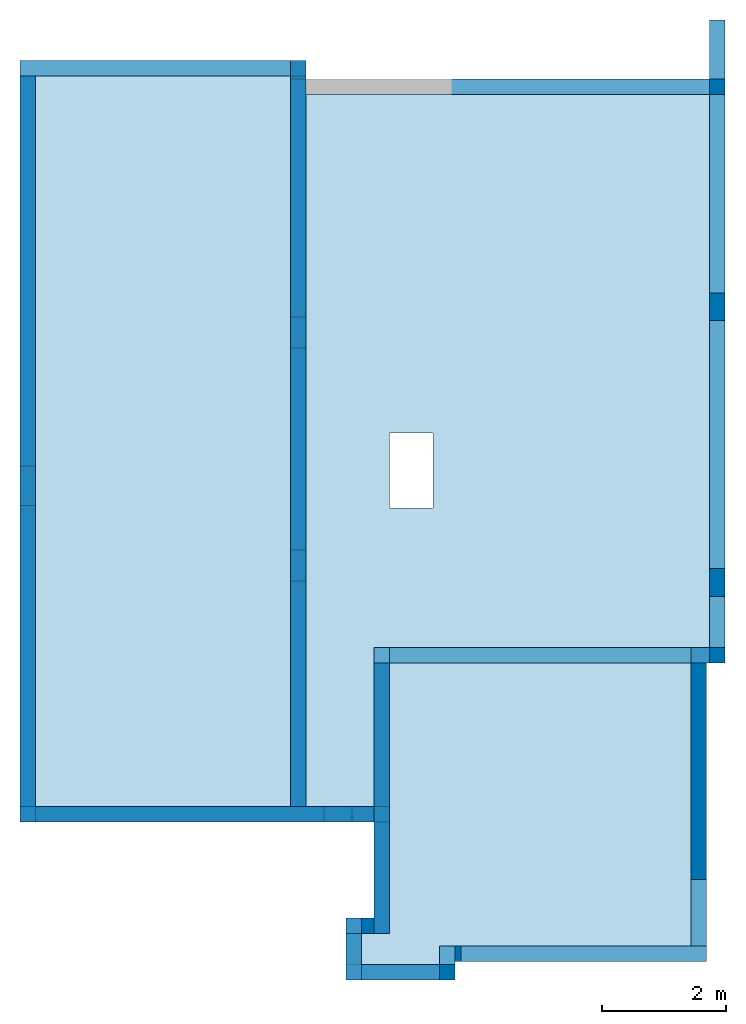
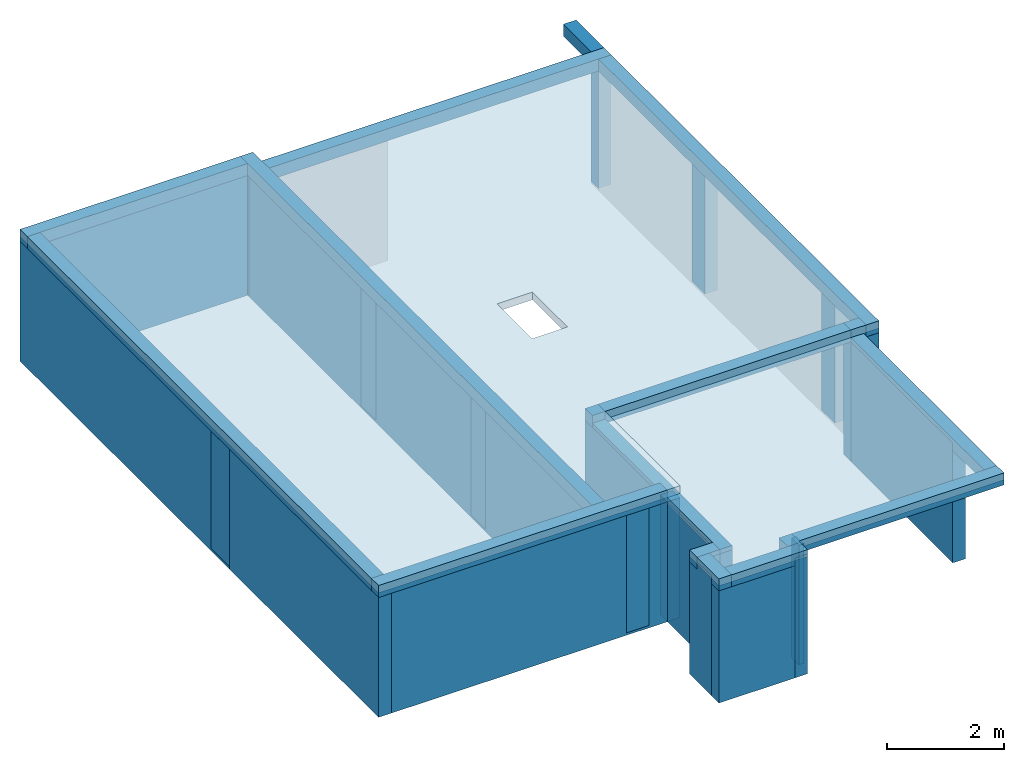
# One storey, part 1 of 2: 17 beams, 17 walls, 7 columns, 2 slabs.
"""IFC4 building model written with IfcOpenShell, lengths in millimetres."""

import ifcopenshell
import ifcopenshell.guid

model = None  # the IFC model being written
_history = None  # IfcOwnerHistory: only IFC2X3 demands one
_inside = {}  # id of a spatial element -> (the spatial element, [elements in it])
_under = {}  # id of a project, library or spatial element -> (it, [spatial elements below it])
_declared = {}  # id of a project -> (the project, [libraries it declares])
_typed = {}  # id of a type object -> (the type object, [elements of that type])
_made_of = {}  # id of a material, layer set ... -> (it, [elements and type objects made of it])


def new_model(schema):
    """Start an empty IFC model of exactly this schema.

    Asked for "IFC4X3", IfcOpenShell would pick the latest addendum, in which some entities
    have other attributes; the version numbers below select the first issue.
    IFC2X3 requires an IfcOwnerHistory on every rooted entity: one is made here for all.
    """
    global model, _history
    if schema == "IFC4X3":
        model = ifcopenshell.file(schema_version=(4, 3, 0, 0))
    else:
        model = ifcopenshell.file(schema=schema)
    _inside.clear()
    _under.clear()
    _declared.clear()
    _typed.clear()
    _made_of.clear()
    _history = None
    if model.schema == "IFC2X3":
        org = make("IfcOrganization", Name="unknown")
        user = make(
            "IfcPersonAndOrganization",
            ThePerson=make("IfcPerson", FamilyName="unknown"),
            TheOrganization=org,
        )
        app = make(
            "IfcApplication",
            ApplicationDeveloper=org,
            Version="unknown",
            ApplicationFullName="unknown",
            ApplicationIdentifier="unknown",
        )
        _history = make(
            "IfcOwnerHistory",
            OwningUser=user,
            OwningApplication=app,
            ChangeAction="ADDED",
            CreationDate=0,
        )
    return model


def make(cls, **values):
    """One entity of the class cls with the attributes given. An attribute that is None is left unset."""
    return model.create_entity(
        cls, **{name: value for name, value in values.items() if value is not None}
    )


def entity(cls, *values):
    """Any entity or typed value of the class cls, its attributes in the order of the schema. None: left unset."""
    e = model.create_entity(cls)
    for i, value in enumerate(values):
        if value is not None:
            e[i] = value
    return e


def rooted(cls, **values):
    """An entity with a GlobalId (a new one), such as an element, a storey or a relation."""
    return make(cls, GlobalId=ifcopenshell.guid.new(), OwnerHistory=_history, **values)


def si_unit(unit_type, name, prefix=None):
    """IfcSIUnit, for example si_unit("LENGTHUNIT", "METRE", prefix="MILLI")."""
    return make("IfcSIUnit", UnitType=unit_type, Prefix=prefix, Name=name)


def converted_unit(unit_type, name, factor, base, dimensions=None, offset=None):
    """IfcConversionBasedUnit, such as the inch: factor (a typed value) times the base unit."""
    return make(
        "IfcConversionBasedUnit"
        if offset is None
        else "IfcConversionBasedUnitWithOffset",
        ConversionOffset=offset,
        Dimensions=None
        if dimensions is None
        else entity("IfcDimensionalExponents", *dimensions),
        UnitType=unit_type,
        Name=name,
        ConversionFactor=make(
            "IfcMeasureWithUnit", ValueComponent=factor, UnitComponent=base
        ),
    )


def assignment(units):
    """IfcUnitAssignment: the units of a project."""
    return None if units is None else make("IfcUnitAssignment", Units=units)


def point(xyz):
    """IfcCartesianPoint."""
    return None if xyz is None else make("IfcCartesianPoint", Coordinates=xyz)


def direction(xyz):
    """IfcDirection."""
    return None if xyz is None else make("IfcDirection", DirectionRatios=xyz)


def frame(location, z_axis=None, x_axis=None):
    """IfcAxis2Placement3D, a coordinate frame: its origin and axes. An axis left out is left unset."""
    return make(
        "IfcAxis2Placement3D",
        Location=point(location),
        Axis=direction(z_axis),
        RefDirection=direction(x_axis),
    )


def frame_2d(location, x_axis=None):
    """IfcAxis2Placement2D, a coordinate frame in the plane: its origin and x axis."""
    return make(
        "IfcAxis2Placement2D", Location=point(location), RefDirection=direction(x_axis)
    )


def origin():
    """The frame at (0, 0, 0) with its axes left unset."""
    return frame((0.0, 0.0, 0.0))


def origin_with_axes():
    """The frame at (0, 0, 0) with the z axis (0, 0, 1) and the x axis (1, 0, 0) written out."""
    return frame((0.0, 0.0, 0.0), z_axis=(0.0, 0.0, 1.0), x_axis=(1.0, 0.0, 0.0))


def place(relative_to, where):
    """IfcLocalPlacement: puts the frame where relative to a parent placement (None: the world)."""
    return make(
        "IfcLocalPlacement", PlacementRelTo=relative_to, RelativePlacement=where
    )


def context(
    kind, dimensions, precision=None, world=None, true_north=None, identifier=None
):
    """IfcGeometricRepresentationContext, for example the 3D "Model" context."""
    return make(
        "IfcGeometricRepresentationContext",
        ContextIdentifier=identifier,
        ContextType=kind,
        CoordinateSpaceDimension=dimensions,
        Precision=precision,
        WorldCoordinateSystem=world,
        TrueNorth=true_north,
    )


def subcontext(parent, identifier, kind, view, scale=None):
    """IfcGeometricRepresentationSubContext, for example "Body" below "Model"."""
    return make(
        "IfcGeometricRepresentationSubContext",
        ContextIdentifier=identifier,
        ContextType=kind,
        ParentContext=parent,
        TargetScale=scale,
        TargetView=view,
    )


def project(units=None, contexts=None):
    """IfcProject with its units and contexts."""
    return rooted(
        "IfcProject",
        Name="project",
        RepresentationContexts=contexts,
        UnitsInContext=assignment(units),
    )


def spatial(cls, under=None, at=None, **own):
    """A site, building, storey or space (cls), placed at a placement, below another one or the project."""
    s = rooted(cls, ObjectPlacement=at, **own)
    if under is not None:
        _under.setdefault(under.id(), (under, []))[1].append(s)
    return s


def polyline(points):
    """IfcPolyline through the points."""
    return make("IfcPolyline", Points=[point(p) for p in points])


def profile(cls, at=None, kind="AREA", **sizes):
    """A parametric profile (cls). Its sizes go by their IFC names, for example OverallWidth=200.0."""
    return make(cls, ProfileType=kind, Position=at, **sizes)


def rectangle(**sizes):
    """IfcRectangleProfileDef."""
    return profile("IfcRectangleProfileDef", **sizes)


def outline(outer, holes=None, kind="AREA"):
    """IfcArbitraryClosedProfileDef: a profile drawn as a closed curve; with holes, ...WithVoids."""
    if holes is None:
        return make("IfcArbitraryClosedProfileDef", ProfileType=kind, OuterCurve=outer)
    return make(
        "IfcArbitraryProfileDefWithVoids",
        ProfileType=kind,
        OuterCurve=outer,
        InnerCurves=holes,
    )


def extrude(swept, where, along, depth):
    """IfcExtrudedAreaSolid: the profile swept, set in the frame where, extruded along a direction by depth."""
    return make(
        "IfcExtrudedAreaSolid",
        SweptArea=swept,
        Position=where,
        ExtrudedDirection=direction(along),
        Depth=depth,
    )


def clip(a, b, op="DIFFERENCE"):
    """IfcBooleanClippingResult: the solid a cut by the half space b."""
    return make(
        "IfcBooleanClippingResult", Operator=op, FirstOperand=a, SecondOperand=b
    )


def bounded_halfspace(plane, agree, where, boundary):
    """IfcPolygonalBoundedHalfSpace: a half space limited to a polygon's prism."""
    return make(
        "IfcPolygonalBoundedHalfSpace",
        BaseSurface=make("IfcPlane", Position=plane),
        AgreementFlag=agree,
        Position=where,
        PolygonalBoundary=boundary,
    )


def shape(context_of_items, identifier, shape_type, items):
    """IfcShapeRepresentation: the items that make up one representation, for example the "Body"."""
    return make(
        "IfcShapeRepresentation",
        ContextOfItems=context_of_items,
        RepresentationIdentifier=identifier,
        RepresentationType=shape_type,
        Items=items,
    )


def material(Name=None, Category=None):
    """IfcMaterial."""
    return make("IfcMaterial", Name=Name, Category=Category)


def layer(
    of_material, thickness, ventilated=None, Name=None, Category=None, Priority=None
):
    """IfcMaterialLayer: one layer of a wall or slab, of a material (None: an air gap)."""
    return make(
        "IfcMaterialLayer",
        Material=of_material,
        LayerThickness=thickness,
        IsVentilated=ventilated,
        Name=Name,
        Category=Category,
        Priority=Priority,
    )


def layer_set(layers, Name=None):
    """IfcMaterialLayerSet."""
    return make("IfcMaterialLayerSet", MaterialLayers=layers, LayerSetName=Name)


def layer_usage(for_layer_set, set_direction, sense, offset, extent=None):
    """IfcMaterialLayerSetUsage: how a layer set lies in its element."""
    return make(
        "IfcMaterialLayerSetUsage",
        ForLayerSet=for_layer_set,
        LayerSetDirection=set_direction,
        DirectionSense=sense,
        OffsetFromReferenceLine=offset,
        ReferenceExtent=extent,
    )


def material_profile(
    of_material, cross_section, Name=None, Category=None, Priority=None
):
    """IfcMaterialProfile: a cross section and its material."""
    return make(
        "IfcMaterialProfile",
        Name=Name,
        Material=of_material,
        Profile=cross_section,
        Priority=Priority,
        Category=Category,
    )


def profile_set(profiles, Name=None, composite=None):
    """IfcMaterialProfileSet."""
    return make(
        "IfcMaterialProfileSet",
        Name=Name,
        MaterialProfiles=profiles,
        CompositeProfile=composite,
    )


def profile_usage(for_profile_set, cardinal=None, extent=None):
    """IfcMaterialProfileSetUsage: how a profile set lies along its element."""
    return make(
        "IfcMaterialProfileSetUsage",
        ForProfileSet=for_profile_set,
        CardinalPoint=cardinal,
        ReferenceExtent=extent,
    )


def made_of(thing, what):
    """Note that an element or type object is made of a material, layer set ...; save() writes the relation."""
    if what is not None:
        _made_of.setdefault(what.id(), (what, []))[1].append(thing)
    return thing


def element(
    cls,
    number,
    at=None,
    inside=None,
    cuts=None,
    type_object=None,
    material=None,
    context=None,
    identifier="Body",
    shape_type=None,
    held_by="IfcProductDefinitionShape",
    body=None,
    shapes=None,
    **own,
):
    """One element of the class cls, such as IfcWall. Its Tag is "e" and its number.

    at: its placement. inside: the storey or other place that contains it. cuts: it is an
    opening in that element (IfcRelVoidsElement). A single representation is given by context,
    identifier, shape_type and body (its items); several are given by shapes. held_by: the class
    of the entity that holds the representations. save() writes the other relations.
    """
    e = rooted(cls, Tag="e%d" % number, ObjectPlacement=at, **own)
    if body is not None:
        shapes = [shape(context, identifier, shape_type, body)]
    if shapes is not None:
        e.Representation = make(held_by, Representations=shapes)
    if inside is not None:
        _inside.setdefault(inside.id(), (inside, []))[1].append(e)
    if cuts is not None:
        rooted(
            "IfcRelVoidsElement", RelatingBuildingElement=cuts, RelatedOpeningElement=e
        )
    if type_object is not None:
        _typed.setdefault(type_object.id(), (type_object, []))[1].append(e)
    return made_of(e, material)


def aggregate(whole, parts):
    """IfcRelAggregates: a whole, such as a stair, and the parts it consists of."""
    return rooted("IfcRelAggregates", RelatingObject=whole, RelatedObjects=parts)


def save(model, path):
    """Write the relations noted so far, then the file.

    IfcRelAggregates (storeys below a building ...), IfcRelContainedInSpatialStructure (elements
    in a storey), IfcRelDefinesByType, IfcRelAssociatesMaterial and IfcRelDeclares: one each for
    every whole, place, type object, material and project.
    """
    for whole, parts in _under.values():
        aggregate(whole, parts)
    for where, things in _inside.values():
        rooted(
            "IfcRelContainedInSpatialStructure",
            RelatedElements=things,
            RelatingStructure=where,
        )
    for kind, things in _typed.values():
        rooted("IfcRelDefinesByType", RelatedObjects=things, RelatingType=kind)
    for what, things in _made_of.values():
        rooted("IfcRelAssociatesMaterial", RelatedObjects=things, RelatingMaterial=what)
    for by, libraries in _declared.values():
        rooted("IfcRelDeclares", RelatingContext=by, RelatedDefinitions=libraries)
    model.write(path)


model = new_model("IFC4")

# Units and contexts
model_context = context("Model", 3, precision=1e-05, world=origin())
plan_context = context("Plan", 3, precision=1e-05, world=origin())
body_context = subcontext(model_context, "Body", "Model", "MODEL_VIEW")
ifc_project = project(units=[si_unit("LENGTHUNIT", "METRE", prefix="MILLI"), converted_unit("PLANEANGLEUNIT", "DEGREE", entity("IfcPlaneAngleMeasure", 0.0174532925199433), si_unit("PLANEANGLEUNIT", "RADIAN"), dimensions=[0, 0, 0, 0, 0, 0, 0]), si_unit("AREAUNIT", "SQUARE_METRE"), si_unit("VOLUMEUNIT", "CUBIC_METRE")], contexts=[model_context, plan_context])

# Building, storey
building_placement = place(None, origin())
building = spatial("IfcBuilding", under=ifc_project, at=building_placement, CompositionType="ELEMENT")
storey_placement = place(building_placement, frame((0.0, 0.0, 3200.0)))
storey = spatial("IfcBuildingStorey", under=building, at=storey_placement, Name="1. Kondygnacja", CompositionType="ELEMENT", Elevation=3200.0)

# Columns
ifc_material_1 = material()
ifc_material_profile_1 = material_profile(ifc_material_1, rectangle(XDim=450.0, YDim=250.0, at=frame_2d((-125.0, 225.0), x_axis=(-8.084397349092695e-15, 1.0))))
ifc_profile_set_1 = profile_set([ifc_material_profile_1])
ifc_profile_usage_1 = profile_usage(ifc_profile_set_1)
column_1_placement = place(storey_placement, frame((28011.87089786272, 20028.40820697432, -200.0)))
element("IfcColumnStandardCase", 1, at=column_1_placement, inside=storey, material=ifc_profile_usage_1, context=body_context, shape_type="SweptSolid", body=[
    extrude(rectangle(XDim=450.0, YDim=250.0, at=frame_2d((-125.0, 225.0), x_axis=(-8.084397349092695e-15, 1.0))), frame((250.0000000000036, 0.0, 0.0), z_axis=(0.0, 0.0, 1.0), x_axis=(1.0, 0.0, 0.0)), (0.0, 0.0, 1.0), 2450.0),
])
ifc_material_2 = material()
ifc_material_profile_2 = material_profile(ifc_material_2, rectangle(XDim=450.0, YDim=250.0, at=frame_2d((-125.0000000000036, 225.0), x_axis=(-8.084397349092695e-15, 1.0))))
ifc_profile_set_2 = profile_set([ifc_material_profile_2])
ifc_profile_usage_2 = profile_usage(ifc_profile_set_2)
column_2_placement = place(storey_placement, frame((28011.87089786275, 15588.40820697432, -200.0)))
element("IfcColumnStandardCase", 2, at=column_2_placement, inside=storey, material=ifc_profile_usage_2, context=body_context, shape_type="SweptSolid", body=[
    extrude(rectangle(XDim=450.0, YDim=250.0, at=frame_2d((-125.0000000000036, 225.0), x_axis=(-8.084397349092695e-15, 1.0))), frame((250.0000000000036, 0.0, 0.0), z_axis=(0.0, 0.0, 1.0), x_axis=(1.0, 0.0, 0.0)), (0.0, 0.0, 1.0), 2450.0),
])
ifc_material_3 = material()
ifc_material_profile_3 = material_profile(ifc_material_3, rectangle(XDim=450.0, YDim=250.0, at=frame_2d((225.0, 124.9999999999945), x_axis=(1.0, -2.425319204727809e-14))))
ifc_profile_set_3 = profile_set([ifc_material_profile_3])
ifc_profile_usage_3 = profile_usage(ifc_profile_set_3)
column_3_placement = place(storey_placement, frame((21801.87089786276, 11958.40820697433, -200.0)))
element("IfcColumnStandardCase", 3, at=column_3_placement, inside=storey, material=ifc_profile_usage_3, context=body_context, shape_type="SweptSolid", body=[
    extrude(rectangle(XDim=450.0, YDim=250.0, at=frame_2d((225.0, 124.9999999999945), x_axis=(1.0, -2.425319204727809e-14))), frame((0.0, 1.091393642127514e-11, 0.0), z_axis=(0.0, 0.0, 1.0), x_axis=(1.0, 0.0, 0.0)), (0.0, 0.0, 1.0), 2450.0),
])
ifc_material_4 = material()
ifc_material_profile_4 = material_profile(ifc_material_4, rectangle(XDim=629.9999999999891, YDim=250.0, at=frame_2d((-125.0, 314.9999999999964), x_axis=(-5.774569535066311e-15, 1.0))))
ifc_profile_set_4 = profile_set([ifc_material_profile_4])
ifc_profile_usage_4 = profile_usage(ifc_profile_set_4)
column_4_placement = place(storey_placement, frame((16911.8708978628, 17058.40820697431, -200.0)))
element("IfcColumnStandardCase", 4, at=column_4_placement, inside=storey, material=ifc_profile_usage_4, context=body_context, shape_type="SweptSolid", body=[
    extrude(rectangle(XDim=629.9999999999891, YDim=250.0, at=frame_2d((-125.0, 314.9999999999964), x_axis=(-5.774569535066311e-15, 1.0))), frame((250.0000000000036, 0.0, 0.0), z_axis=(0.0, 0.0, 1.0), x_axis=(1.0, 0.0, 0.0)), (0.0, 0.0, 1.0), 2450.0),
])
ifc_material_5 = material()
ifc_material_profile_5 = material_profile(ifc_material_5, rectangle(XDim=500.0, YDim=250.0, at=frame_2d((-125.0, 250.0), x_axis=(0.0, 1.0))))
ifc_profile_set_5 = profile_set([ifc_material_profile_5])
ifc_profile_usage_5 = profile_usage(ifc_profile_set_5)
column_5_placement = place(storey_placement, frame((21261.87089786276, 19588.40820697429, -200.0)))
element("IfcColumnStandardCase", 5, at=column_5_placement, inside=storey, material=ifc_profile_usage_5, context=body_context, shape_type="SweptSolid", body=[
    extrude(rectangle(XDim=500.0, YDim=250.0, at=frame_2d((-125.0, 250.0), x_axis=(0.0, 1.0))), frame((250.0, 0.0, 0.0), z_axis=(0.0, 0.0, 1.0), x_axis=(1.0, 0.0, 0.0)), (0.0, 0.0, 1.0), 2450.0),
])
ifc_material_6 = material()
ifc_material_profile_6 = material_profile(ifc_material_6, rectangle(XDim=500.0000000000182, YDim=250.0, at=frame_2d((-125.0, 250.0000000000091), x_axis=(0.0, 1.0))))
ifc_profile_set_6 = profile_set([ifc_material_profile_6])
ifc_profile_usage_6 = profile_usage(ifc_profile_set_6)
column_6_placement = place(storey_placement, frame((21261.87089786277, 15838.40820697432, -200.0)))
element("IfcColumnStandardCase", 6, at=column_6_placement, inside=storey, material=ifc_profile_usage_6, context=body_context, shape_type="SweptSolid", body=[
    extrude(rectangle(XDim=500.0000000000182, YDim=250.0, at=frame_2d((-125.0, 250.0000000000091), x_axis=(0.0, 1.0))), frame((250.0, 0.0, 0.0), z_axis=(0.0, 0.0, 1.0), x_axis=(1.0, 0.0, 0.0)), (0.0, 0.0, 1.0), 2450.0),
])
ifc_material_7 = material()
ifc_material_profile_7 = material_profile(ifc_material_7, rectangle(XDim=250.0, YDim=250.0, at=frame_2d((125.0, -125.0), x_axis=(0.0, -1.0))))
ifc_profile_set_7 = profile_set([ifc_material_profile_7])
ifc_profile_usage_7 = profile_usage(ifc_profile_set_7)
column_7_placement = place(storey_placement, frame((28011.87089786269, 23668.40820697431, -200.0)))
element("IfcColumnStandardCase", 7, at=column_7_placement, inside=storey, material=ifc_profile_usage_7, context=body_context, shape_type="SweptSolid", body=[
    extrude(rectangle(XDim=250.0, YDim=250.0, at=frame_2d((125.0, -125.0), x_axis=(0.0, -1.0))), frame((0.0, 250.0, 0.0), z_axis=(0.0, 0.0, 1.0), x_axis=(1.0, 0.0, 0.0)), (0.0, 0.0, 1.0), 2450.0),
])

# Beams
ifc_material_8 = material()
ifc_material_profile_8 = material_profile(ifc_material_8, rectangle(XDim=250.0, YDim=250.0, at=frame_2d((125.0, -125.0), x_axis=(0.0, 1.0))))
ifc_profile_set_8 = profile_set([ifc_material_profile_8])
ifc_profile_usage_8 = profile_usage(ifc_profile_set_8)
beam_1_placement = place(storey_placement, frame((28261.87089786276, 14518.40820697431, 2250.0), z_axis=(0.0, 0.0, 1.0), x_axis=(-7.156679620508288e-15, 1.0, 0.0)))
element("IfcBeamStandardCase", 8, at=beam_1_placement, inside=storey, material=ifc_profile_usage_8, context=body_context, shape_type="SweptSolid", body=[
    extrude(rectangle(XDim=250.0, YDim=250.0, at=frame_2d((125.0, -125.0), x_axis=(0.0, 1.0))), frame((0.0, 0.0, 0.0), z_axis=(1.0, 0.0, 0.0), x_axis=(0.0, 0.0, 1.0)), (0.0, 0.0, 1.0), 9150.0),
])
ifc_material_9 = material()
ifc_material_profile_9 = material_profile(ifc_material_9, rectangle(XDim=250.0, YDim=250.0, at=frame_2d((125.0, -125.0), x_axis=(0.0, 1.0))))
ifc_profile_set_9 = profile_set([ifc_material_profile_9])
ifc_profile_usage_9 = profile_usage(ifc_profile_set_9)
beam_2_placement = place(storey_placement, frame((22861.87089786273, 14518.40820697432, 2250.0), z_axis=(0.0, 0.0, 1.0), x_axis=(1.0, -4.125542977114295e-15, 0.0)))
element("IfcBeamStandardCase", 9, at=beam_2_placement, inside=storey, material=ifc_profile_usage_9, context=body_context, shape_type="SweptSolid", body=[
    extrude(rectangle(XDim=250.0, YDim=250.0, at=frame_2d((125.0, -125.0), x_axis=(0.0, 1.0))), frame((0.0, 0.0, 0.0), z_axis=(1.0, 0.0, 0.0), x_axis=(0.0, 0.0, 1.0)), (0.0, 0.0, 1.0), 4850.000000000022),
])
ifc_material_10 = material()
ifc_material_profile_10 = material_profile(ifc_material_10, rectangle(XDim=250.0, YDim=250.0, at=frame_2d((125.0, -125.0), x_axis=(0.0, 1.0))))
ifc_profile_set_10 = profile_set([ifc_material_profile_10])
ifc_profile_usage_10 = profile_usage(ifc_profile_set_10)
beam_3_placement = place(storey_placement, frame((27711.87089786276, 14518.4082069743, 2250.0), z_axis=(0.0, 0.0, 1.0), x_axis=(1.0, 6.063298011819375e-15, 0.0)))
element("IfcBeamStandardCase", 10, at=beam_3_placement, inside=storey, material=ifc_profile_usage_10, context=body_context, shape_type="SweptSolid", body=[
    extrude(rectangle(XDim=250.0, YDim=250.0, at=frame_2d((125.0, -125.0), x_axis=(0.0, 1.0))), frame((0.0, 0.0, 0.0), z_axis=(1.0, 0.0, 0.0), x_axis=(0.0, 0.0, 1.0)), (0.0, 0.0, 1.0), 300.0000000000073),
])
ifc_material_11 = material()
ifc_material_profile_11 = material_profile(ifc_material_11, rectangle(XDim=250.0, YDim=250.0, at=frame_2d((125.0, -125.0), x_axis=(0.0, 1.0))))
ifc_profile_set_11 = profile_set([ifc_material_profile_11])
ifc_profile_usage_11 = profile_usage(ifc_profile_set_11)
beam_4_placement = place(storey_placement, frame((22611.87089786273, 14518.40820697432, 2090.0), z_axis=(0.0, 0.0, 1.0), x_axis=(5.017901802885102e-15, -1.0, 0.0)))
element("IfcBeamStandardCase", 11, at=beam_4_placement, inside=storey, material=ifc_profile_usage_11, context=body_context, shape_type="SweptSolid", body=[
    extrude(rectangle(XDim=250.0, YDim=250.0, at=frame_2d((125.0, -125.0), x_axis=(0.0, 1.0))), frame((0.0, 0.0, 0.0), z_axis=(1.0, 0.0, 0.0), x_axis=(0.0, 0.0, 1.0)), (0.0, 0.0, 1.0), 4350.000000000016),
])
ifc_material_12 = material()
ifc_material_profile_12 = material_profile(ifc_material_12, rectangle(XDim=250.0, YDim=250.0, at=frame_2d((125.0, -125.0), x_axis=(0.0, 1.0))))
ifc_profile_set_12 = profile_set([ifc_material_profile_12])
ifc_profile_usage_12 = profile_usage(ifc_profile_set_12)
beam_5_placement = place(storey_placement, frame((22161.87089786276, 10168.4082069743, 2090.0), z_axis=(0.0, 0.0, 1.0), x_axis=(1.0, 8.084397349092695e-15, 0.0)))
element("IfcBeamStandardCase", 12, at=beam_5_placement, inside=storey, material=ifc_profile_usage_12, context=body_context, shape_type="SweptSolid", body=[
    extrude(rectangle(XDim=250.0, YDim=250.0, at=frame_2d((125.0, -125.0), x_axis=(0.0, 1.0))), frame((0.0, 0.0, 0.0), z_axis=(1.0, 0.0, 0.0), x_axis=(0.0, 0.0, 1.0)), (0.0, 0.0, 1.0), 450.0),
])
ifc_material_13 = material()
ifc_material_profile_13 = material_profile(ifc_material_13, rectangle(XDim=250.0, YDim=250.0, at=frame_2d((125.0, -125.0), x_axis=(0.0, 1.0))))
ifc_profile_set_13 = profile_set([ifc_material_profile_13])
ifc_profile_usage_13 = profile_usage(ifc_profile_set_13)
beam_6_placement = place(storey_placement, frame((22161.87089786276, 10168.4082069743, 2090.0), z_axis=(0.0, 0.0, 1.0), x_axis=(0.0, -1.0, 0.0)))
element("IfcBeamStandardCase", 13, at=beam_6_placement, inside=storey, material=ifc_profile_usage_13, context=body_context, shape_type="SweptSolid", body=[
    extrude(rectangle(XDim=250.0, YDim=250.0, at=frame_2d((125.0, -125.0), x_axis=(0.0, 1.0))), frame((0.0, 0.0, 0.0), z_axis=(1.0, 0.0, 0.0), x_axis=(0.0, 0.0, 1.0)), (0.0, 0.0, 1.0), 749.9999999999964),
])
ifc_material_14 = material()
ifc_material_profile_14 = material_profile(ifc_material_14, rectangle(XDim=250.0, YDim=250.0, at=frame_2d((125.0, -125.0), x_axis=(0.0, 1.0))))
ifc_profile_set_14 = profile_set([ifc_material_profile_14])
ifc_profile_usage_14 = profile_usage(ifc_profile_set_14)
beam_7_placement = place(storey_placement, frame((22411.87089786276, 9418.408206974304, 2090.0)))
element("IfcBeamStandardCase", 14, at=beam_7_placement, inside=storey, material=ifc_profile_usage_14, context=body_context, shape_type="SweptSolid", body=[
    extrude(rectangle(XDim=250.0, YDim=250.0, at=frame_2d((125.0, -125.0), x_axis=(0.0, 1.0))), frame((0.0, 0.0, 0.0), z_axis=(1.0, 0.0, 0.0), x_axis=(0.0, 0.0, 1.0)), (0.0, 0.0, 1.0), 1500.0),
])
ifc_material_15 = material()
ifc_material_profile_15 = material_profile(ifc_material_15, rectangle(XDim=250.0, YDim=250.0, at=frame_2d((125.0, -125.0), x_axis=(0.0, 1.0))))
ifc_profile_set_15 = profile_set([ifc_material_profile_15])
ifc_profile_usage_15 = profile_usage(ifc_profile_set_15)
beam_8_placement = place(storey_placement, frame((23911.87089786276, 9668.408206974304, 2090.0), z_axis=(0.0, 0.0, 1.0), x_axis=(0.0, 1.0, 0.0)))
element("IfcBeamStandardCase", 15, at=beam_8_placement, inside=storey, material=ifc_profile_usage_15, context=body_context, shape_type="SweptSolid", body=[
    extrude(rectangle(XDim=250.0, YDim=250.0, at=frame_2d((125.0, -125.0), x_axis=(0.0, 1.0))), frame((0.0, 0.0, 0.0), z_axis=(1.0, 0.0, 0.0), x_axis=(0.0, 0.0, 1.0)), (0.0, 0.0, 1.0), 300.0),
])
ifc_material_16 = material()
ifc_material_profile_16 = material_profile(ifc_material_16, rectangle(XDim=250.0, YDim=250.0, at=frame_2d((125.0, -125.0), x_axis=(0.0, 1.0))))
ifc_profile_set_16 = profile_set([ifc_material_profile_16])
ifc_profile_usage_16 = profile_usage(ifc_profile_set_16)
beam_9_placement = place(storey_placement, frame((27961.87089786276, 9968.408206974304, 2090.0), z_axis=(0.0, 0.0, 1.0), x_axis=(-1.0, 0.0, 0.0)))
element("IfcBeamStandardCase", 16, at=beam_9_placement, inside=storey, material=ifc_profile_usage_16, context=body_context, shape_type="SweptSolid", body=[
    extrude(rectangle(XDim=250.0, YDim=250.0, at=frame_2d((125.0, -125.0), x_axis=(0.0, 1.0))), frame((0.0, 0.0, 0.0), z_axis=(1.0, 0.0, 0.0), x_axis=(0.0, 0.0, 1.0)), (0.0, 0.0, 1.0), 4050.0),
])
ifc_material_17 = material()
ifc_material_profile_17 = material_profile(ifc_material_17, rectangle(XDim=250.0, YDim=250.0, at=frame_2d((125.0, -125.0), x_axis=(0.0, 1.0))))
ifc_profile_set_17 = profile_set([ifc_material_profile_17])
ifc_profile_usage_17 = profile_usage(ifc_profile_set_17)
beam_10_placement = place(storey_placement, frame((27961.87089786276, 9968.408206974304, 2090.0), z_axis=(0.0, 0.0, 1.0), x_axis=(0.0, 1.0, 0.0)))
element("IfcBeamStandardCase", 17, at=beam_10_placement, inside=storey, material=ifc_profile_usage_17, context=body_context, shape_type="SweptSolid", body=[
    extrude(rectangle(XDim=250.0, YDim=250.0, at=frame_2d((125.0, -125.0), x_axis=(0.0, 1.0))), frame((0.0, 0.0, 0.0), z_axis=(1.0, 0.0, 0.0), x_axis=(0.0, 0.0, 1.0)), (0.0, 0.0, 1.0), 4550.0),
])
ifc_material_18 = material()
ifc_material_profile_18 = material_profile(ifc_material_18, rectangle(XDim=250.0, YDim=250.0, at=frame_2d((125.0, -125.0), x_axis=(0.0, 1.0))))
ifc_profile_set_18 = profile_set([ifc_material_profile_18])
ifc_profile_usage_18 = profile_usage(ifc_profile_set_18)
beam_11_placement = place(storey_placement, frame((22611.87089786273, 14518.40820697432, 2250.0), z_axis=(0.0, 0.0, 1.0), x_axis=(1.0, 1.455191522836685e-14, 0.0)))
element("IfcBeamStandardCase", 18, at=beam_11_placement, inside=storey, material=ifc_profile_usage_18, context=body_context, shape_type="SweptSolid", body=[
    extrude(rectangle(XDim=250.0, YDim=250.0, at=frame_2d((125.0, -125.0), x_axis=(0.0, 1.0))), frame((0.0, 0.0, 0.0), z_axis=(1.0, 0.0, 0.0), x_axis=(0.0, 0.0, 1.0)), (0.0, 0.0, 1.0), 250.0),
])
ifc_material_19 = material()
ifc_material_profile_19 = material_profile(ifc_material_19, rectangle(XDim=250.0, YDim=250.0, at=frame_2d((125.0, -125.0), x_axis=(0.0, 1.0))))
ifc_profile_set_19 = profile_set([ifc_material_profile_19])
ifc_profile_usage_19 = profile_usage(ifc_profile_set_19)
beam_12_placement = place(storey_placement, frame((22611.87089786276, 12208.40820697432, 2250.0), z_axis=(0.0, 0.0, 1.0), x_axis=(-1.0, 2.361495015129737e-14, 0.0)))
element("IfcBeamStandardCase", 19, at=beam_12_placement, inside=storey, material=ifc_profile_usage_19, context=body_context, shape_type="SweptSolid", body=[
    extrude(rectangle(XDim=250.0, YDim=250.0, at=frame_2d((125.0, -125.0), x_axis=(0.0, 1.0))), frame((0.0, 0.0, 0.0), z_axis=(1.0, 0.0, 0.0), x_axis=(0.0, 0.0, 1.0)), (0.0, 0.0, 1.0), 5699.999999999931),
])
ifc_material_20 = material()
ifc_material_profile_20 = material_profile(ifc_material_20, rectangle(XDim=250.0, YDim=250.0, at=frame_2d((125.0, -125.0), x_axis=(0.0, 1.0))))
ifc_profile_set_20 = profile_set([ifc_material_profile_20])
ifc_profile_usage_20 = profile_usage(ifc_profile_set_20)
beam_13_placement = place(storey_placement, frame((28011.87089786276, 24868.40820697431, 2250.0), z_axis=(0.0, 0.0, 1.0), x_axis=(-6.127122201417575e-14, -1.0, 0.0)))
element("IfcBeamStandardCase", 20, at=beam_13_placement, inside=storey, material=ifc_profile_usage_20, context=body_context, shape_type="SweptSolid", body=[
    extrude(rectangle(XDim=250.0, YDim=250.0, at=frame_2d((125.0, -125.0), x_axis=(0.0, 1.0))), frame((0.0, 0.0, 0.0), z_axis=(1.0, 0.0, 0.0), x_axis=(0.0, 0.0, 1.0)), (0.0, 0.0, 1.0), 950.0000000000073),
])
ifc_material_21 = material()
ifc_material_profile_21 = material_profile(ifc_material_21, rectangle(XDim=249.9999999999964, YDim=250.0, at=frame_2d((125.0, -124.9999999999982), x_axis=(0.0, 1.0))))
ifc_profile_set_21 = profile_set([ifc_material_profile_21])
ifc_profile_usage_21 = profile_usage(ifc_profile_set_21)
beam_14_placement = place(storey_placement, frame((28261.8708978627, 23918.4082069743, 2250.0), z_axis=(0.0, 0.0, 1.0), x_axis=(-1.0, -2.694799116364255e-15, 0.0)))
element("IfcBeamStandardCase", 21, at=beam_14_placement, inside=storey, material=ifc_profile_usage_21, context=body_context, shape_type="SweptSolid", body=[
    extrude(rectangle(XDim=249.9999999999964, YDim=250.0, at=frame_2d((125.0, -124.9999999999982), x_axis=(0.0, 1.0))), frame((0.0, 0.0, 0.0), z_axis=(1.0, 0.0, 0.0), x_axis=(0.0, 0.0, 1.0)), (0.0, 0.0, 1.0), 6749.999999999942),
])
ifc_material_22 = material()
ifc_material_profile_22 = material_profile(ifc_material_22, rectangle(XDim=249.9999999999964, YDim=250.0, at=frame_2d((125.0, -124.9999999999982), x_axis=(0.0, 1.0))))
ifc_profile_set_22 = profile_set([ifc_material_profile_22])
ifc_profile_usage_22 = profile_usage(ifc_profile_set_22)
beam_15_placement = place(storey_placement, frame((21511.87089786278, 12208.40820697429, 2250.0), z_axis=(0.0, 0.0, 1.0), x_axis=(-1.817474841178206e-15, 1.0, 0.0)))
element("IfcBeamStandardCase", 22, at=beam_15_placement, inside=storey, material=ifc_profile_usage_22, context=body_context, shape_type="SweptSolid", body=[
    extrude(rectangle(XDim=249.9999999999964, YDim=250.0, at=frame_2d((125.0, -124.9999999999982), x_axis=(0.0, 1.0))), frame((0.0, 0.0, 0.0), z_axis=(1.0, 0.0, 0.0), x_axis=(0.0, 0.0, 1.0)), (0.0, 0.0, 1.0), 12010.00000000001),
])
ifc_material_23 = material()
ifc_material_profile_23 = material_profile(ifc_material_23, rectangle(XDim=250.0, YDim=250.0, at=frame_2d((125.0, -125.0), x_axis=(0.0, 1.0))))
ifc_profile_set_23 = profile_set([ifc_material_profile_23])
ifc_profile_usage_23 = profile_usage(ifc_profile_set_23)
beam_16_placement = place(storey_placement, frame((17161.87089786283, 12208.40820697446, 2250.0), z_axis=(0.0, 0.0, 1.0), x_axis=(-6.187038787571021e-15, 1.0, 0.0)))
element("IfcBeamStandardCase", 23, at=beam_16_placement, inside=storey, material=ifc_profile_usage_23, context=body_context, shape_type="SweptSolid", body=[
    extrude(rectangle(XDim=250.0, YDim=250.0, at=frame_2d((125.0, -125.0), x_axis=(0.0, 1.0))), frame((0.0, 0.0, 0.0), z_axis=(1.0, 0.0, 0.0), x_axis=(0.0, 0.0, 1.0)), (0.0, 0.0, 1.0), 11759.99999999985),
])
ifc_material_24 = material()
ifc_material_profile_24 = material_profile(ifc_material_24, rectangle(XDim=250.0, YDim=250.0, at=frame_2d((125.0, -125.0), x_axis=(0.0, 1.0))))
ifc_profile_set_24 = profile_set([ifc_material_profile_24])
ifc_profile_usage_24 = profile_usage(ifc_profile_set_24)
beam_17_placement = place(storey_placement, frame((21261.87089786276, 24218.40820697431, 2250.0), z_axis=(0.0, 0.0, 1.0), x_axis=(-1.0, 0.0, 0.0)))
element("IfcBeamStandardCase", 24, at=beam_17_placement, inside=storey, material=ifc_profile_usage_24, context=body_context, shape_type="SweptSolid", body=[
    extrude(rectangle(XDim=250.0, YDim=250.0, at=frame_2d((125.0, -125.0), x_axis=(0.0, 1.0))), frame((0.0, 0.0, 0.0), z_axis=(1.0, 0.0, 0.0), x_axis=(0.0, 0.0, 1.0)), (0.0, 0.0, 1.0), 4350.0),
])

# Slabs
ifc_material_25 = material()
ifc_layer_1 = layer(ifc_material_25, 150.0)
ifc_layer_set_1 = layer_set([ifc_layer_1])
ifc_layer_usage_1 = layer_usage(ifc_layer_set_1, "AXIS3", "POSITIVE", 0.0)
slab_1_placement = place(storey_placement, frame((22161.87089786276, 9418.408206974304, 2190.0)))
element("IfcSlabStandardCase", 25, at=slab_1_placement, inside=storey, material=ifc_layer_usage_1, PredefinedType="FLOOR", context=body_context, shape_type="SweptSolid", body=[
    extrude(outline(polyline([(449.9999999999782, 5100.000000000016), (450.0, 1000.0), (0.0, 1000.0), (0.0, 0.0), (1750.0, 0.0), (1750.0, 300.0), (5800.0, 300.0000000000182), (5800.0, 5100.0), (449.9999999999782, 5100.000000000016)])), origin_with_axes(), (0.0, 0.0, 1.0), 150.0),
])
ifc_material_26 = material()
ifc_layer_2 = layer(ifc_material_26, 160.0)
ifc_layer_set_2 = layer_set([ifc_layer_2])
ifc_layer_usage_2 = layer_usage(ifc_layer_set_2, "AXIS3", "POSITIVE", 0.0)
slab_2_placement = place(storey_placement, frame((16911.87089786276, 11958.40820697434, 2340.0)))
element("IfcSlabStandardCase", 26, at=slab_2_placement, inside=storey, material=ifc_layer_usage_2, PredefinedType="FLOOR", context=body_context, shape_type="SweptSolid", body=[
    extrude(outline(polyline([(6.548361852765083e-11, 1.200533006340265e-10), (5949.999999999993, 0.0), (5950.0, 2559.999999999967), (11350.0, 2559.999999999967), (11349.99999999994, 11959.99999999997), (4600.0, 11959.99999999995), (4600.0, 12259.99999999997), (0.0, 12259.99999999997), (6.548361852765083e-11, 1.200533006340265e-10)]), holes=[polyline([(5950.0, 5059.999999999965), (5950.0, 6259.999999999965), (6650.0, 6259.999999999965), (6650.0, 5059.999999999965), (5950.0, 5059.999999999965)])]), origin_with_axes(), (0.0, 0.0, 1.0), 160.0),
])

# Walls
ifc_material_27 = material()
ifc_layer_3 = layer(ifc_material_27, 250.0)
ifc_layer_set_3 = layer_set([ifc_layer_3])
ifc_layer_usage_3 = layer_usage(ifc_layer_set_3, "AXIS2", "POSITIVE", 0.0)
wall_1_placement = place(storey_placement, frame((17161.87089786283, 11958.40820697446, -250.0), z_axis=(0.0, 0.0, 1.0), x_axis=(-5.706633422889125e-15, 1.0, 0.0)))
element("IfcWallStandardCase", 27, at=wall_1_placement, inside=storey, material=ifc_layer_usage_3, context=body_context, shape_type="SweptSolid", body=[
    extrude(rectangle(XDim=5099.999999999855, YDim=250.0, at=frame_2d((2549.999999999927, 125.0), x_axis=(1.0, 0.0))), origin_with_axes(), (0.0, 0.0, 1.0), 2500.0),
])
ifc_material_28 = material()
ifc_layer_4 = layer(ifc_material_28, 250.0)
ifc_layer_set_4 = layer_set([ifc_layer_4])
ifc_layer_usage_4 = layer_usage(ifc_layer_set_4, "AXIS2", "POSITIVE", 0.0)
wall_2_placement = place(storey_placement, frame((22611.87089786276, 12208.40820697432, -250.0), z_axis=(0.0, 0.0, 1.0), x_axis=(-1.0, 2.503196426897999e-14, 0.0)))
element("IfcWallStandardCase", 28, at=wall_2_placement, inside=storey, material=ifc_layer_usage_4, context=body_context, shape_type="Clipping", body=[
    clip(extrude(rectangle(XDim=5449.999999999931, YDim=250.0, at=frame_2d((2724.999999999965, 125.0), x_axis=(1.0, 0.0))), origin_with_axes(), (0.0, 0.0, 1.0), 2500.0), bounded_halfspace(frame((585.0000000000005, 124.9999999999983, 50.0), z_axis=(0.0, 0.0, -1.0), x_axis=(-2.503196426898e-14, 1.0, 0.0)), True, origin_with_axes(), polyline([(810.0000000000036, -1.551981784676393e-12), (809.9999999999974, 250.0000000000003), (359.9999999999974, 250.0000000000017), (360.0000000000036, -8.343988089639445e-14), (810.0000000000036, -1.551981784676393e-12)]))),
])
ifc_material_29 = material()
ifc_layer_5 = layer(ifc_material_29, 250.0)
ifc_layer_set_5 = layer_set([ifc_layer_5])
ifc_layer_usage_5 = layer_usage(ifc_layer_set_5, "AXIS2", "POSITIVE", 0.0)
wall_3_placement = place(storey_placement, frame((22611.87089786275, 11958.40820697432, -250.0), z_axis=(0.0, 0.0, 1.0), x_axis=(2.032390395023283e-15, -1.0, 0.0)))
element("IfcWallStandardCase", 29, at=wall_3_placement, inside=storey, material=ifc_layer_usage_5, context=body_context, shape_type="SweptSolid", body=[
    extrude(rectangle(XDim=1790.000000000018, YDim=250.0, at=frame_2d((895.0000000000091, 125.0), x_axis=(1.0, 0.0))), origin_with_axes(), (0.0, 0.0, 1.0), 2500.0),
])
ifc_material_30 = material()
ifc_layer_6 = layer(ifc_material_30, 250.0)
ifc_layer_set_6 = layer_set([ifc_layer_6])
ifc_layer_usage_6 = layer_usage(ifc_layer_set_6, "AXIS2", "POSITIVE", 0.0)
wall_4_placement = place(storey_placement, frame((22611.87089786276, 10418.4082069743, -250.0), z_axis=(0.0, 0.0, 1.0), x_axis=(-1.0, 0.0, 0.0)))
element("IfcWallStandardCase", 30, at=wall_4_placement, inside=storey, material=ifc_layer_usage_6, context=body_context, shape_type="SweptSolid", body=[
    extrude(rectangle(XDim=200.0, YDim=250.0, at=frame_2d((100.0, 125.0), x_axis=(1.0, 0.0))), origin_with_axes(), (0.0, 0.0, 1.0), 2500.0),
])
ifc_material_31 = material()
ifc_layer_7 = layer(ifc_material_31, 250.0)
ifc_layer_set_7 = layer_set([ifc_layer_7])
ifc_layer_usage_7 = layer_usage(ifc_layer_set_7, "AXIS2", "POSITIVE", 0.0)
wall_5_placement = place(storey_placement, frame((22161.87089786276, 10418.4082069743, -250.0), z_axis=(0.0, 0.0, 1.0), x_axis=(0.0, -1.0, 0.0)))
element("IfcWallStandardCase", 31, at=wall_5_placement, inside=storey, material=ifc_layer_usage_7, context=body_context, shape_type="SweptSolid", body=[
    extrude(rectangle(XDim=750.0, YDim=250.0, at=frame_2d((375.0, 125.0), x_axis=(1.0, 0.0))), origin_with_axes(), (0.0, 0.0, 1.0), 2500.0),
])
ifc_material_32 = material()
ifc_layer_8 = layer(ifc_material_32, 250.0)
ifc_layer_set_8 = layer_set([ifc_layer_8])
ifc_layer_usage_8 = layer_usage(ifc_layer_set_8, "AXIS2", "POSITIVE", 0.0)
wall_6_placement = place(storey_placement, frame((22161.87089786276, 9418.408206974304, -250.0)))
element("IfcWallStandardCase", 32, at=wall_6_placement, inside=storey, material=ifc_layer_usage_8, context=body_context, shape_type="SweptSolid", body=[
    extrude(rectangle(XDim=1500.0, YDim=250.0, at=frame_2d((750.0, 125.0), x_axis=(1.0, 0.0))), origin_with_axes(), (0.0, 0.0, 1.0), 2500.0),
])
ifc_material_33 = material()
ifc_layer_9 = layer(ifc_material_33, 250.0)
ifc_layer_set_9 = layer_set([ifc_layer_9])
ifc_layer_usage_9 = layer_usage(ifc_layer_set_9, "AXIS2", "POSITIVE", 0.0)
wall_7_placement = place(storey_placement, frame((23911.87089786276, 9418.408206974304, -250.0), z_axis=(0.0, 0.0, 1.0), x_axis=(0.0, 1.0, 0.0)))
element("IfcWallStandardCase", 33, at=wall_7_placement, inside=storey, material=ifc_layer_usage_9, context=body_context, shape_type="SweptSolid", body=[
    extrude(rectangle(XDim=550.0, YDim=250.0, at=frame_2d((275.0, 125.0), x_axis=(1.0, 0.0))), origin_with_axes(), (0.0, 0.0, 1.0), 2500.0),
])
ifc_material_34 = material()
ifc_layer_10 = layer(ifc_material_34, 250.0)
ifc_layer_set_10 = layer_set([ifc_layer_10])
ifc_layer_usage_10 = layer_usage(ifc_layer_set_10, "AXIS2", "POSITIVE", 0.0)
wall_8_placement = place(storey_placement, frame((27711.87089786276, 14518.4082069743, -250.0), z_axis=(0.0, 0.0, 1.0), x_axis=(0.0, -1.0, 0.0)))
element("IfcWallStandardCase", 34, at=wall_8_placement, inside=storey, material=ifc_layer_usage_10, context=body_context, shape_type="SweptSolid", body=[
    extrude(rectangle(XDim=3480.0, YDim=250.0, at=frame_2d((1740.0, 125.0), x_axis=(1.0, 0.0))), origin_with_axes(), (0.0, 0.0, 1.0), 2500.0),
])
ifc_material_35 = material()
ifc_layer_11 = layer(ifc_material_35, 250.0)
ifc_layer_set_11 = layer_set([ifc_layer_11])
ifc_layer_usage_11 = layer_usage(ifc_layer_set_11, "AXIS2", "POSITIVE", 0.0)
wall_9_placement = place(storey_placement, frame((28011.87089786276, 14768.4082069743, -250.0), z_axis=(0.0, 0.0, 1.0), x_axis=(-1.0, 0.0, 0.0)))
element("IfcWallStandardCase", 35, at=wall_9_placement, inside=storey, material=ifc_layer_usage_11, context=body_context, shape_type="SweptSolid", body=[
    extrude(rectangle(XDim=300.0000000000036, YDim=250.0, at=frame_2d((150.0000000000018, 125.0), x_axis=(1.0, 0.0))), origin_with_axes(), (0.0, 0.0, 1.0), 2500.0),
])
ifc_material_36 = material()
ifc_layer_12 = layer(ifc_material_36, 250.0)
ifc_layer_set_12 = layer_set([ifc_layer_12])
ifc_layer_usage_12 = layer_usage(ifc_layer_set_12, "AXIS2", "POSITIVE", 0.0)
wall_10_placement = place(storey_placement, frame((21511.87089786276, 23918.40820697428, -250.0), z_axis=(0.0, 0.0, 1.0), x_axis=(0.0, 1.0, 0.0)))
element("IfcWallStandardCase", 36, at=wall_10_placement, inside=storey, material=ifc_layer_usage_12, context=body_context, shape_type="SweptSolid", body=[
    extrude(rectangle(XDim=50.00000000002183, YDim=250.0, at=frame_2d((25.00000000001091, 125.0), x_axis=(1.0, 0.0))), origin_with_axes(), (0.0, 0.0, 1.0), 2500.0),
])
ifc_material_37 = material()
ifc_layer_13 = layer(ifc_material_37, 250.0)
ifc_layer_set_13 = layer_set([ifc_layer_13])
ifc_layer_usage_13 = layer_usage(ifc_layer_set_13, "AXIS2", "POSITIVE", 0.0)
wall_11_placement = place(storey_placement, frame((21511.87089786276, 24218.40820697431, -250.0), z_axis=(0.0, 0.0, 1.0), x_axis=(-1.0, 0.0, 0.0)))
element("IfcWallStandardCase", 37, at=wall_11_placement, inside=storey, material=ifc_layer_usage_13, context=body_context, shape_type="SweptSolid", body=[
    extrude(rectangle(XDim=4350.0, YDim=250.0, at=frame_2d((2175.0, 125.0), x_axis=(1.0, 0.0))), origin_with_axes(), (0.0, 0.0, 1.0), 2500.0),
])
ifc_material_38 = material()
ifc_layer_14 = layer(ifc_material_38, 250.0)
ifc_layer_set_14 = layer_set([ifc_layer_14])
ifc_layer_usage_14 = layer_usage(ifc_layer_set_14, "AXIS2", "POSITIVE", 0.0)
wall_12_placement = place(storey_placement, frame((16911.87089786276, 24218.40820697431, -250.0), z_axis=(0.0, 0.0, 1.0), x_axis=(6.097171185069916e-15, -1.0, 0.0)))
element("IfcWallStandardCase", 38, at=wall_12_placement, inside=storey, material=ifc_layer_usage_14, context=body_context, shape_type="Clipping", body=[
    clip(extrude(rectangle(XDim=7159.999999999993, YDim=250.0, at=frame_2d((3579.999999999996, 125.0), x_axis=(1.0, 0.0))), origin_with_axes(), (0.0, 0.0, 1.0), 2500.0), bounded_halfspace(frame((6844.999999999997, 125.0000000000019, 50.0), z_axis=(0.0, 0.0, -1.0), x_axis=(6.097171185069916e-15, 1.0, 0.0)), True, origin_with_axes(), polyline([(7159.999999999993, 0.0), (7159.999999999995, 250.0), (6530.000000000006, 250.0000000000002), (6530.000000000004, 2.032390395022675e-13), (7159.999999999993, 0.0)]))),
])
ifc_material_39 = material()
ifc_layer_15 = layer(ifc_material_39, 250.0)
ifc_layer_set_15 = layer_set([ifc_layer_15])
ifc_layer_usage_15 = layer_usage(ifc_layer_set_15, "AXIS2", "POSITIVE", 0.0)
wall_13_placement = place(storey_placement, frame((21511.87089786278, 12208.40820697429, -250.0), z_axis=(0.0, 0.0, 1.0), x_axis=(-1.864036963497037e-15, 1.0, 0.0)))
element("IfcWallStandardCase", 39, at=wall_13_placement, inside=storey, material=ifc_layer_usage_15, context=body_context, shape_type="Clipping", body=[
    clip(clip(extrude(rectangle(XDim=11709.99999999999, YDim=250.0, at=frame_2d((5854.999999999995, 125.0), x_axis=(1.0, 0.0))), origin_with_axes(), (0.0, 0.0, 1.0), 2500.0), bounded_halfspace(frame((7629.999999999993, 125.0000000000003, 50.0), z_axis=(0.0, 0.0, -1.0), x_axis=(-1.864036963497037e-15, -1.0, 0.0)), True, origin_with_axes(), polyline([(7379.999999999994, 250.0000000000008), (7379.999999999993, 7.95322437758736e-13), (7879.999999999993, -1.36696043989783e-13), (7879.999999999994, 249.9999999999999), (7379.999999999994, 250.0000000000008)]))), bounded_halfspace(frame((3880.000000000039, 125.0, 50.0), z_axis=(0.0, 0.0, -1.0), x_axis=(-1.864036963497037e-15, -1.0, 0.0)), True, origin_with_axes(), polyline([(3630.00000000003, 250.0000000000005), (3630.000000000029, 5.095034366891293e-13), (4130.000000000047, -4.225150450594227e-13), (4130.000000000048, 249.9999999999996), (3630.00000000003, 250.0000000000005)]))),
])
ifc_material_40 = material()
ifc_layer_16 = layer(ifc_material_40, 250.0)
ifc_layer_set_16 = layer_set([ifc_layer_16])
ifc_layer_usage_16 = layer_usage(ifc_layer_set_16, "AXIS2", "POSITIVE", 0.0)
wall_14_placement = place(storey_placement, frame((28261.87089786276, 14768.40820697431, -250.0), z_axis=(0.0, 0.0, 1.0), x_axis=(-1.0, -7.275957614183426e-15, 0.0)))
element("IfcWallStandardCase", 40, at=wall_14_placement, inside=storey, material=ifc_layer_usage_16, context=body_context, shape_type="SweptSolid", body=[
    extrude(rectangle(XDim=250.0, YDim=250.0, at=frame_2d((125.0, 125.0), x_axis=(1.0, 0.0))), origin_with_axes(), (0.0, 0.0, 1.0), 2500.0),
])
ifc_material_41 = material()
ifc_layer_17 = layer(ifc_material_41, 250.0)
ifc_layer_set_17 = layer_set([ifc_layer_17])
ifc_layer_usage_17 = layer_usage(ifc_layer_set_17, "AXIS2", "POSITIVE", 0.0)
wall_15_placement = place(storey_placement, frame((22611.87089786276, 12208.40820697432, -250.0), z_axis=(0.0, 0.0, 1.0), x_axis=(-2.91038304567337e-14, -1.0, 0.0)))
element("IfcWallStandardCase", 41, at=wall_15_placement, inside=storey, material=ifc_layer_usage_17, context=body_context, shape_type="SweptSolid", body=[
    extrude(rectangle(XDim=250.0, YDim=250.0, at=frame_2d((125.0, 125.0), x_axis=(1.0, 0.0))), origin_with_axes(), (0.0, 0.0, 1.0), 2500.0),
])
ifc_material_42 = material()
ifc_layer_18 = layer(ifc_material_42, 250.0)
ifc_layer_set_18 = layer_set([ifc_layer_18])
ifc_layer_usage_18 = layer_usage(ifc_layer_set_18, "AXIS2", "POSITIVE", 0.0)
wall_16_placement = place(storey_placement, frame((23911.87089786276, 9718.408206974304, -250.0)))
element("IfcWallStandardCase", 42, at=wall_16_placement, inside=storey, material=ifc_layer_usage_18, context=body_context, shape_type="SweptSolid", body=[
    extrude(rectangle(XDim=100.0, YDim=250.0, at=frame_2d((50.0, 125.0), x_axis=(1.0, 0.0))), origin_with_axes(), (0.0, 0.0, 1.0), 2500.0),
])
ifc_material_43 = material()
ifc_layer_19 = layer(ifc_material_43, 250.0)
ifc_layer_set_19 = layer_set([ifc_layer_19])
ifc_layer_usage_19 = layer_usage(ifc_layer_set_19, "AXIS2", "POSITIVE", 0.0)
wall_17_placement = place(storey_placement, frame((22611.87089786273, 14768.4082069743, -250.0), z_axis=(0.0, 0.0, 1.0), x_axis=(1.136868377216168e-14, -1.0, 0.0)))
element("IfcWallStandardCase", 43, at=wall_17_placement, inside=storey, material=ifc_layer_usage_19, context=body_context, shape_type="SweptSolid", body=[
    extrude(rectangle(XDim=2559.999999999982, YDim=250.0, at=frame_2d((1279.999999999991, 125.0), x_axis=(1.0, 0.0))), origin_with_axes(), (0.0, 0.0, 1.0), 2500.0),
])

save(model, "model.ifc")
